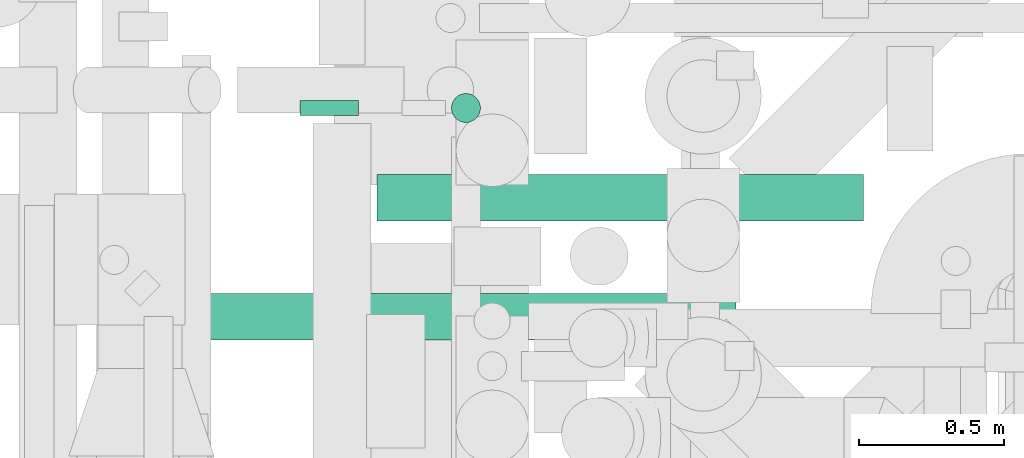
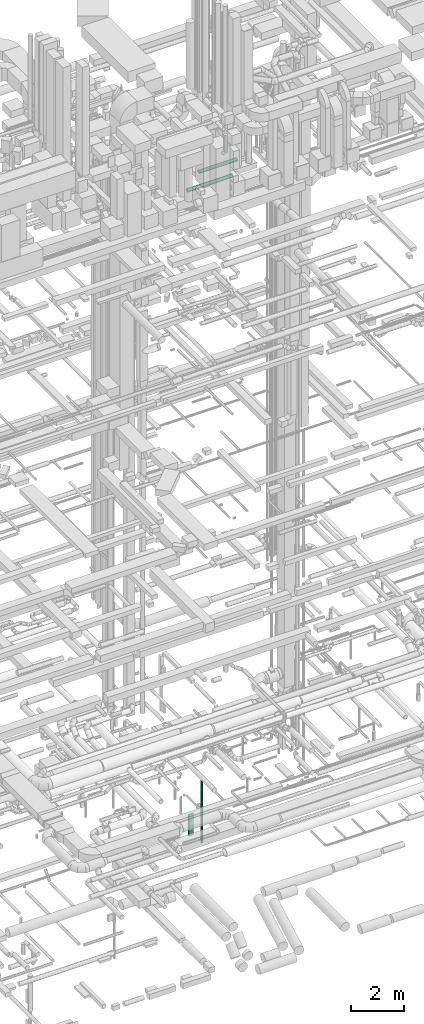
# One storey, part 52 of 337: 4 flow segments.
"""IFC2X3 building model written with IfcOpenShell, lengths in millimetres."""

import ifcopenshell
import ifcopenshell.guid

model = None  # the IFC model being written
_history = None  # IfcOwnerHistory: only IFC2X3 demands one
_inside = {}  # id of a spatial element -> (the spatial element, [elements in it])
_under = {}  # id of a project, library or spatial element -> (it, [spatial elements below it])
_declared = {}  # id of a project -> (the project, [libraries it declares])
_typed = {}  # id of a type object -> (the type object, [elements of that type])
_made_of = {}  # id of a material, layer set ... -> (it, [elements and type objects made of it])


def new_model(schema):
    """Start an empty IFC model of exactly this schema.

    Asked for "IFC4X3", IfcOpenShell would pick the latest addendum, in which some entities
    have other attributes; the version numbers below select the first issue.
    IFC2X3 requires an IfcOwnerHistory on every rooted entity: one is made here for all.
    """
    global model, _history
    if schema == "IFC4X3":
        model = ifcopenshell.file(schema_version=(4, 3, 0, 0))
    else:
        model = ifcopenshell.file(schema=schema)
    _inside.clear()
    _under.clear()
    _declared.clear()
    _typed.clear()
    _made_of.clear()
    _history = None
    if model.schema == "IFC2X3":
        org = make("IfcOrganization", Name="unknown")
        user = make(
            "IfcPersonAndOrganization",
            ThePerson=make("IfcPerson", FamilyName="unknown"),
            TheOrganization=org,
        )
        app = make(
            "IfcApplication",
            ApplicationDeveloper=org,
            Version="unknown",
            ApplicationFullName="unknown",
            ApplicationIdentifier="unknown",
        )
        _history = make(
            "IfcOwnerHistory",
            OwningUser=user,
            OwningApplication=app,
            ChangeAction="ADDED",
            CreationDate=0,
        )
    return model


def make(cls, **values):
    """One entity of the class cls with the attributes given. An attribute that is None is left unset."""
    return model.create_entity(
        cls, **{name: value for name, value in values.items() if value is not None}
    )


def entity(cls, *values):
    """Any entity or typed value of the class cls, its attributes in the order of the schema. None: left unset."""
    e = model.create_entity(cls)
    for i, value in enumerate(values):
        if value is not None:
            e[i] = value
    return e


def rooted(cls, **values):
    """An entity with a GlobalId (a new one), such as an element, a storey or a relation."""
    return make(cls, GlobalId=ifcopenshell.guid.new(), OwnerHistory=_history, **values)


def si_unit(unit_type, name, prefix=None):
    """IfcSIUnit, for example si_unit("LENGTHUNIT", "METRE", prefix="MILLI")."""
    return make("IfcSIUnit", UnitType=unit_type, Prefix=prefix, Name=name)


def converted_unit(unit_type, name, factor, base, dimensions=None, offset=None):
    """IfcConversionBasedUnit, such as the inch: factor (a typed value) times the base unit."""
    return make(
        "IfcConversionBasedUnit"
        if offset is None
        else "IfcConversionBasedUnitWithOffset",
        ConversionOffset=offset,
        Dimensions=None
        if dimensions is None
        else entity("IfcDimensionalExponents", *dimensions),
        UnitType=unit_type,
        Name=name,
        ConversionFactor=make(
            "IfcMeasureWithUnit", ValueComponent=factor, UnitComponent=base
        ),
    )


def derived_unit(unit_type, elements):
    """IfcDerivedUnit: a product of units, each with its exponent."""
    return make(
        "IfcDerivedUnit",
        Elements=[
            make("IfcDerivedUnitElement", Unit=unit, Exponent=power)
            for unit, power in elements
        ],
        UnitType=unit_type,
    )


def assignment(units):
    """IfcUnitAssignment: the units of a project."""
    return None if units is None else make("IfcUnitAssignment", Units=units)


def point(xyz):
    """IfcCartesianPoint."""
    return None if xyz is None else make("IfcCartesianPoint", Coordinates=xyz)


def direction(xyz):
    """IfcDirection."""
    return None if xyz is None else make("IfcDirection", DirectionRatios=xyz)


def frame(location, z_axis=None, x_axis=None):
    """IfcAxis2Placement3D, a coordinate frame: its origin and axes. An axis left out is left unset."""
    return make(
        "IfcAxis2Placement3D",
        Location=point(location),
        Axis=direction(z_axis),
        RefDirection=direction(x_axis),
    )


def frame_2d(location, x_axis=None):
    """IfcAxis2Placement2D, a coordinate frame in the plane: its origin and x axis."""
    return make(
        "IfcAxis2Placement2D", Location=point(location), RefDirection=direction(x_axis)
    )


def origin():
    """The frame at (0, 0, 0) with its axes left unset."""
    return frame((0.0, 0.0, 0.0))


def origin_2d_with_axis():
    """The frame at (0, 0) in the plane with the x axis (1, 0) written out."""
    return frame_2d((0.0, 0.0), x_axis=(1.0, 0.0))


def place(relative_to, where):
    """IfcLocalPlacement: puts the frame where relative to a parent placement (None: the world)."""
    return make(
        "IfcLocalPlacement", PlacementRelTo=relative_to, RelativePlacement=where
    )


def context(
    kind, dimensions, precision=None, world=None, true_north=None, identifier=None
):
    """IfcGeometricRepresentationContext, for example the 3D "Model" context."""
    return make(
        "IfcGeometricRepresentationContext",
        ContextIdentifier=identifier,
        ContextType=kind,
        CoordinateSpaceDimension=dimensions,
        Precision=precision,
        WorldCoordinateSystem=world,
        TrueNorth=true_north,
    )


def subcontext(parent, identifier, kind, view, scale=None):
    """IfcGeometricRepresentationSubContext, for example "Body" below "Model"."""
    return make(
        "IfcGeometricRepresentationSubContext",
        ContextIdentifier=identifier,
        ContextType=kind,
        ParentContext=parent,
        TargetScale=scale,
        TargetView=view,
    )


def project(units=None, contexts=None):
    """IfcProject with its units and contexts."""
    return rooted(
        "IfcProject",
        Name="project",
        RepresentationContexts=contexts,
        UnitsInContext=assignment(units),
    )


def spatial(cls, under=None, at=None, **own):
    """A site, building, storey or space (cls), placed at a placement, below another one or the project."""
    s = rooted(cls, ObjectPlacement=at, **own)
    if under is not None:
        _under.setdefault(under.id(), (under, []))[1].append(s)
    return s


def profile(cls, at=None, kind="AREA", **sizes):
    """A parametric profile (cls). Its sizes go by their IFC names, for example OverallWidth=200.0."""
    return make(cls, ProfileType=kind, Position=at, **sizes)


def rectangle(**sizes):
    """IfcRectangleProfileDef."""
    return profile("IfcRectangleProfileDef", **sizes)


def circle(**sizes):
    """IfcCircleProfileDef."""
    return profile("IfcCircleProfileDef", **sizes)


def extrude(swept, where, along, depth):
    """IfcExtrudedAreaSolid: the profile swept, set in the frame where, extruded along a direction by depth."""
    return make(
        "IfcExtrudedAreaSolid",
        SweptArea=swept,
        Position=where,
        ExtrudedDirection=direction(along),
        Depth=depth,
    )


def shape(context_of_items, identifier, shape_type, items):
    """IfcShapeRepresentation: the items that make up one representation, for example the "Body"."""
    return make(
        "IfcShapeRepresentation",
        ContextOfItems=context_of_items,
        RepresentationIdentifier=identifier,
        RepresentationType=shape_type,
        Items=items,
    )


def made_of(thing, what):
    """Note that an element or type object is made of a material, layer set ...; save() writes the relation."""
    if what is not None:
        _made_of.setdefault(what.id(), (what, []))[1].append(thing)
    return thing


def type_object(cls, material=None, **own):
    """A type object (cls), such as IfcWallType, which elements share."""
    return made_of(rooted(cls, **own), material)


def element(
    cls,
    number,
    at=None,
    inside=None,
    cuts=None,
    type_object=None,
    material=None,
    context=None,
    identifier="Body",
    shape_type=None,
    held_by="IfcProductDefinitionShape",
    body=None,
    shapes=None,
    **own,
):
    """One element of the class cls, such as IfcWall. Its Tag is "e" and its number.

    at: its placement. inside: the storey or other place that contains it. cuts: it is an
    opening in that element (IfcRelVoidsElement). A single representation is given by context,
    identifier, shape_type and body (its items); several are given by shapes. held_by: the class
    of the entity that holds the representations. save() writes the other relations.
    """
    e = rooted(cls, Tag="e%d" % number, ObjectPlacement=at, **own)
    if body is not None:
        shapes = [shape(context, identifier, shape_type, body)]
    if shapes is not None:
        e.Representation = make(held_by, Representations=shapes)
    if inside is not None:
        _inside.setdefault(inside.id(), (inside, []))[1].append(e)
    if cuts is not None:
        rooted(
            "IfcRelVoidsElement", RelatingBuildingElement=cuts, RelatedOpeningElement=e
        )
    if type_object is not None:
        _typed.setdefault(type_object.id(), (type_object, []))[1].append(e)
    return made_of(e, material)


def aggregate(whole, parts):
    """IfcRelAggregates: a whole, such as a stair, and the parts it consists of."""
    return rooted("IfcRelAggregates", RelatingObject=whole, RelatedObjects=parts)


def save(model, path):
    """Write the relations noted so far, then the file.

    IfcRelAggregates (storeys below a building ...), IfcRelContainedInSpatialStructure (elements
    in a storey), IfcRelDefinesByType, IfcRelAssociatesMaterial and IfcRelDeclares: one each for
    every whole, place, type object, material and project.
    """
    for whole, parts in _under.values():
        aggregate(whole, parts)
    for where, things in _inside.values():
        rooted(
            "IfcRelContainedInSpatialStructure",
            RelatedElements=things,
            RelatingStructure=where,
        )
    for kind, things in _typed.values():
        rooted("IfcRelDefinesByType", RelatedObjects=things, RelatingType=kind)
    for what, things in _made_of.values():
        rooted("IfcRelAssociatesMaterial", RelatedObjects=things, RelatingMaterial=what)
    for by, libraries in _declared.values():
        rooted("IfcRelDeclares", RelatingContext=by, RelatedDefinitions=libraries)
    model.write(path)


model = new_model("IFC2X3")

# Units and contexts
model_context = context("Model", 3, precision=0.01, world=origin(), true_north=direction((6.12303176911189e-17, 1.0)))
body_context = subcontext(model_context, "Body", "Model", "MODEL_VIEW")
ifc_project = project(units=[si_unit("LENGTHUNIT", "METRE", prefix="MILLI"), si_unit("AREAUNIT", "SQUARE_METRE"), si_unit("VOLUMEUNIT", "CUBIC_METRE"), converted_unit("PLANEANGLEUNIT", "DEGREE", entity("IfcRatioMeasure", 0.0174532925199433), si_unit("PLANEANGLEUNIT", "RADIAN"), dimensions=[0, 0, 0, 0, 0, 0, 0]), si_unit("MASSUNIT", "GRAM", prefix="KILO"), derived_unit("MASSDENSITYUNIT", [(si_unit("MASSUNIT", "GRAM", prefix="KILO"), 1), (si_unit("LENGTHUNIT", "METRE"), -3)]), derived_unit("MOMENTOFINERTIAUNIT", [(si_unit("LENGTHUNIT", "METRE"), 4)]), si_unit("TIMEUNIT", "SECOND"), si_unit("FREQUENCYUNIT", "HERTZ"), si_unit("THERMODYNAMICTEMPERATUREUNIT", "DEGREE_CELSIUS"), derived_unit("THERMALTRANSMITTANCEUNIT", [(si_unit("MASSUNIT", "GRAM", prefix="KILO"), 1), (si_unit("THERMODYNAMICTEMPERATUREUNIT", "KELVIN"), -1), (si_unit("TIMEUNIT", "SECOND"), -3)]), derived_unit("VOLUMETRICFLOWRATEUNIT", [(si_unit("LENGTHUNIT", "METRE"), 3), (si_unit("TIMEUNIT", "SECOND"), -1)]), derived_unit("MASSFLOWRATEUNIT", [(si_unit("MASSUNIT", "GRAM", prefix="KILO"), 1), (si_unit("TIMEUNIT", "SECOND"), -1)]), derived_unit("ROTATIONALFREQUENCYUNIT", [(si_unit("TIMEUNIT", "SECOND"), -1)]), si_unit("ELECTRICCURRENTUNIT", "AMPERE"), si_unit("ELECTRICVOLTAGEUNIT", "VOLT"), si_unit("POWERUNIT", "WATT"), si_unit("FORCEUNIT", "NEWTON", prefix="KILO"), si_unit("ILLUMINANCEUNIT", "LUX"), si_unit("LUMINOUSFLUXUNIT", "LUMEN"), si_unit("LUMINOUSINTENSITYUNIT", "CANDELA"), derived_unit("USERDEFINED", [(si_unit("MASSUNIT", "GRAM", prefix="KILO"), -1), (si_unit("LENGTHUNIT", "METRE"), -2), (si_unit("TIMEUNIT", "SECOND"), 3), (si_unit("LUMINOUSFLUXUNIT", "LUMEN"), 1)]), derived_unit("LINEARVELOCITYUNIT", [(si_unit("LENGTHUNIT", "METRE"), 1), (si_unit("TIMEUNIT", "SECOND"), -1)]), si_unit("PRESSUREUNIT", "PASCAL"), derived_unit("USERDEFINED", [(si_unit("LENGTHUNIT", "METRE"), -2), (si_unit("MASSUNIT", "GRAM", prefix="KILO"), 1), (si_unit("TIMEUNIT", "SECOND"), -2)]), derived_unit("LINEARFORCEUNIT", [(si_unit("MASSUNIT", "GRAM", prefix="KILO"), 1), (si_unit("LENGTHUNIT", "METRE"), 1), (si_unit("TIMEUNIT", "SECOND"), -2), (si_unit("LENGTHUNIT", "METRE"), -1)]), derived_unit("PLANARFORCEUNIT", [(si_unit("MASSUNIT", "GRAM", prefix="KILO"), 1), (si_unit("LENGTHUNIT", "METRE"), 1), (si_unit("TIMEUNIT", "SECOND"), -2), (si_unit("LENGTHUNIT", "METRE"), -2)])], contexts=[model_context])

# Site, building, storey
site_placement = place(None, origin())
site = spatial("IfcSite", under=ifc_project, at=site_placement, CompositionType="ELEMENT")
building_placement = place(site_placement, origin())
building = spatial("IfcBuilding", under=site, at=building_placement, CompositionType="ELEMENT")
storey_placement = place(building_placement, origin())
storey = spatial("IfcBuildingStorey", under=building, at=storey_placement, CompositionType="ELEMENT", Elevation=0.0)

# Flow segments
duct_segment_type_1 = type_object("IfcDuctSegmentType", PredefinedType="NOTDEFINED")
flow_segment_1_placement = place(storey_placement, frame((54933.91, 11771.17, -3250.0)))
element("IfcFlowSegment", 1, at=flow_segment_1_placement, inside=storey, type_object=duct_segment_type_1, context=body_context, shape_type="SweptSolid", body=[
    extrude(rectangle(XDim=50.0000000000016, YDim=199.999999999998, at=origin_2d_with_axis()), frame((100.0, 25.0, 0.0), z_axis=(0.0, 0.0, 1.0), x_axis=(0.0, -1.0, 0.0)), (0.0, 0.0, 1.0), 1000.00005000002),
])
duct_segment_type_2 = type_object("IfcDuctSegmentType", PredefinedType="NOTDEFINED")
flow_segment_2_placement = place(storey_placement, frame((55452.58, 11744.57, -3725.0)))
element("IfcFlowSegment", 2, at=flow_segment_2_placement, inside=storey, type_object=duct_segment_type_2, context=body_context, shape_type="SweptSolid", body=[
    extrude(circle(Radius=50.0, at=origin_2d_with_axis()), frame((51.6, 51.6, 0.0), z_axis=(0.0, 0.0, 1.0), x_axis=(-1.0, 0.0, 0.0)), (0.0, 0.0, 1.0), 2840.00000000001),
])
flow_segment_3_placement = place(storey_placement, frame((54453.52, 10996.22, 27118.4)))
element("IfcFlowSegment", 3, at=flow_segment_3_placement, inside=storey, type_object=duct_segment_type_2, context=body_context, shape_type="SweptSolid", body=[
    extrude(circle(Radius=80.0, at=origin_2d_with_axis()), frame((0.0, 81.6, 81.6), z_axis=(1.0, 0.0, 0.0), x_axis=(0.0, -1.0, 0.0)), (0.0, 0.0, 1.0), 1980.0),
])
flow_segment_4_placement = place(storey_placement, frame((55197.37, 11406.52, 27468.4)))
element("IfcFlowSegment", 4, at=flow_segment_4_placement, inside=storey, type_object=duct_segment_type_2, context=body_context, shape_type="SweptSolid", body=[
    extrude(circle(Radius=80.0, at=origin_2d_with_axis()), frame((0.0, 81.6, 81.6), z_axis=(1.0, 0.0, 0.0), x_axis=(0.0, -1.0, 0.0)), (0.0, 0.0, 1.0), 1674.27920530011),
])

save(model, "model.ifc")
